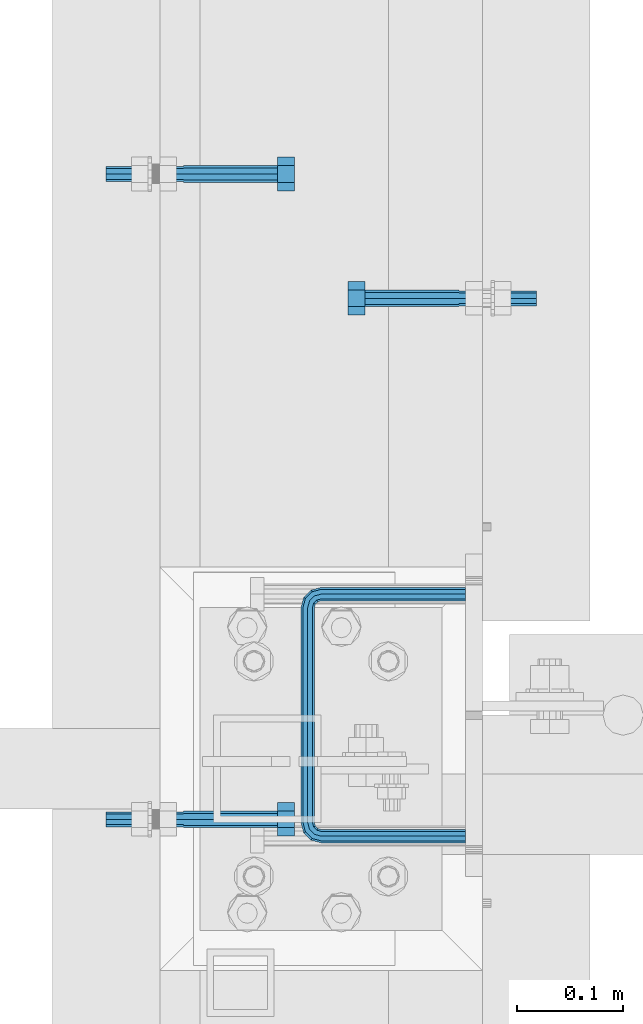
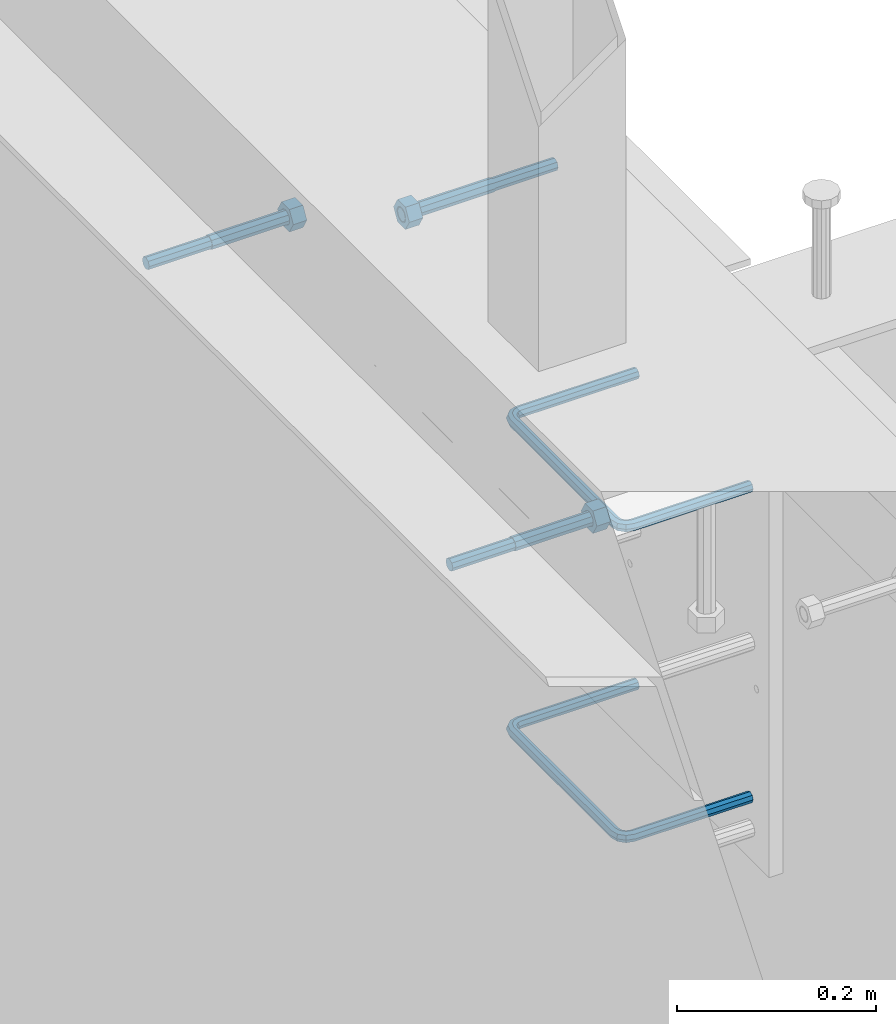
# One storey, part 397 of 975: 5 beams.
"""IFC2X3 building model written with IfcOpenShell, lengths in millimetres."""

from ifc_helpers import new_model, si_unit, frame, origin_with_axes, place, context, subcontext, project, spatial, faceted_brep, material, type_object, element, save


model = new_model("IFC2X3")

# Units and contexts
model_context = context("Model", 3, precision=1e-05, world=origin_with_axes())
body_context = subcontext(model_context, "Body", "Model", "MODEL_VIEW")
ifc_project = project(units=[si_unit("LENGTHUNIT", "METRE", prefix="MILLI"), si_unit("AREAUNIT", "SQUARE_METRE"), si_unit("VOLUMEUNIT", "CUBIC_METRE"), si_unit("MASSUNIT", "GRAM", prefix="KILO"), si_unit("TIMEUNIT", "SECOND"), si_unit("PLANEANGLEUNIT", "RADIAN"), si_unit("SOLIDANGLEUNIT", "STERADIAN"), si_unit("THERMODYNAMICTEMPERATUREUNIT", "DEGREE_CELSIUS"), si_unit("LUMINOUSINTENSITYUNIT", "LUMEN")], contexts=[model_context])

# Site, building, storey
site_placement = place(None, origin_with_axes())
site = spatial("IfcSite", under=ifc_project, at=site_placement, CompositionType="ELEMENT")
building_placement = place(site_placement, origin_with_axes())
building = spatial("IfcBuilding", under=site, at=building_placement, Name="Undefined", CompositionType="ELEMENT")
storey_placement = place(building_placement, origin_with_axes())
storey = spatial("IfcBuildingStorey", under=building, at=storey_placement, Name="Undefined", CompositionType="ELEMENT", Elevation=0.0)

# Beams
ifc_material_1 = material(Name="STEEL/F1554-36")
beam_type_1 = type_object("IfcBeamType", PredefinedType="NOTDEFINED")
beam_1_placement = place(storey_placement, frame((2038.35002654959, 13903.3250486621, 3835.4), z_axis=(0.0, 0.0, -1.0), x_axis=(1.0, 0.0, 0.0)))
element("IfcBeam", 1, at=beam_1_placement, inside=storey, type_object=beam_type_1, material=ifc_material_1, Name="HEADED_ANCHOR_BOLT", context=body_context, shape_type="Brep", body=[
    faceted_brep([(88.9000000184824, 7.94000001861696, -13.7499999799138), (88.8999999527368, 15.8800000758411, 2.00943759409711e-08), (104.774999952569, 15.8800001213949, 6.97191353538074e-08), (104.775000018315, 7.94000006417082, -13.7499999302891), (88.900000064019, -7.94000009583215, -13.7499999799147), (104.775000063852, -7.9400000502792, -13.74999993029), (88.9000000438027, -15.880000153059, 2.00925569515675e-08), (104.775000043643, -15.8800001075042, 6.9716406869702e-08), (88.8999999780608, -7.94000009583488, 13.7500000200998), (104.774999977893, -7.94000005028101, 13.7500000697237), (88.8999999325279, 7.94000001861514, 13.7500000201007), (104.774999932361, 7.940000064169, 13.7500000697246), (88.9000000119959, 3.78780480527439, -7.86545778426807), (88.8999999957159, 6.82538844544797, -5.4430656647246), (88.8999999799416, 8.51112018845743, -1.94260763148395), (88.8999999677944, 8.51112018845652, 1.94260767167179), (88.8999999616899, 6.82538844544615, 5.44306570491244), (88.8999999628249, 3.78780480527257, 7.86545782445592), (88.8999999709849, -3.86089595849626e-08, 8.72999956233434), (88.8999999845473, -3.7878048824914, 7.8654578244541), (88.9000000008309, -6.82538852266407, 5.44306570491153), (88.9000000166052, -8.51112026567444, 1.94260767166998), (88.9000000287488, -8.51112026567353, -1.94260763148577), (88.9000000348606, -6.82538852266407, -5.44306566472642), (88.9000000337182, -3.78780488248958, -7.86545778426898), (88.9000000255583, -3.86080500902608e-08, -8.72999952214832), (104.775000025395, 6.94581103743985e-09, -8.72999947252447), (104.775000011829, 3.78780485082825, -7.86545773464422), (104.774999995549, 6.82538849100092, -5.44306561510075), (104.774999979774, 8.51112023401038, -1.9426075818601), (104.774999967627, 8.51112023401038, 1.94260772129564), (104.774999961523, 6.82538849100092, 5.44306575453629), (104.774999962658, 3.78780485082643, 7.86545787407977), (104.774999970818, 6.94399204803631e-09, 8.7299996119591), (104.77499998438, -3.78780483693754, 7.86545787407886), (104.775000000664, -6.82538847711112, 5.44306575453538), (104.775000016438, -8.51112022012057, 1.94260772129473), (104.775000028581, -8.51112022012057, -1.94260758186101), (104.775000034693, -6.82538847711021, -5.44306561510166), (104.775000033551, -3.78780483693663, -7.86545773464422), (-2.99107341561466e-07, -5.61266007567065, 5.61266007566792), (-4.22995071858168e-07, -7.93750000000728, 0.0), (104.774999998088, -7.93749999999, -4.45652403868735e-11), (104.774999998088, -5.61266007565791, 5.61266007562426), (-1.09139364212751e-11, 1.81898940354586e-12, 7.9375), (104.774999998095, 1.18234311230481e-11, 7.93749999995816), (2.99089151667431e-07, 5.61266007567428, 5.61266007566792), (104.774999998102, 5.61266007568065, 5.61266007562517), (4.22980519942939e-07, 7.93750000001091, 0.0), (104.77499999811, 7.93750000001364, -4.36557456851006e-11), (2.99089151667431e-07, 5.61266007567428, -5.61266007566792), (104.774999998102, 5.61266007568156, -5.61266007571339), (-1.09139364212751e-11, 1.81898940354586e-12, -7.9375), (104.774999998099, 1.2732925824821e-11, -7.93750000004547), (-73.0249999592124, 5.05157065939329, -5.0515715445581), (-73.0249999269472, -1.85405951924622e-07, -7.14400069976364), (-73.0249999328516, -5.0515710302052, -5.05157154455992), (-73.0249999734697, -7.14400018541073, -6.9975976657588e-07), (-73.0250000250016, -5.05157103020611, 5.05157014504039), (-73.0250000572705, -1.85406861419324e-07, 7.1439993002441), (-73.0250000513661, 5.05157065939238, 5.05157014503948), (-73.025000010748, 7.14399981459792, -6.99758857081179e-07), (0.00625003290042514, 5.05157085007795, -5.05157087849238), (0.00625006516929716, 5.27870724909008e-09, -7.1440000336961), (0.00625005926485755, -5.05157083952145, -5.05157087849329), (0.00625001864682417, -7.14399999472516, -3.36940502165817e-08), (0.00624996711121639, -5.05157083952145, 5.05157081110519), (0.00624993484598235, 5.2777977543883e-09, 7.14399996631164), (0.00624994074678398, 5.05157085007704, 5.05157081110701), (0.00624998136845534, 7.14400000528167, -3.36922312271781e-08), (-2.99107341561466e-07, -5.61266007567065, -5.61266007566792), (104.774999998092, -5.612660075657, -5.6126600757143)], [[[0, 1, 2, 3]], [[4, 0, 3, 5]], [[6, 4, 5, 7]], [[8, 6, 7, 9]], [[10, 8, 9, 11]], [[0, 4, 6, 8, 10, 1], [12, 13, 14, 15, 16, 17, 18, 19, 20, 21, 22, 23, 24, 25]], [[12, 25, 26, 27]], [[13, 12, 27, 28]], [[14, 13, 28, 29]], [[15, 14, 29, 30]], [[16, 15, 30, 31]], [[17, 16, 31, 32]], [[18, 17, 32, 33]], [[19, 18, 33, 34]], [[20, 19, 34, 35]], [[21, 20, 35, 36]], [[22, 21, 36, 37]], [[23, 22, 37, 38]], [[24, 23, 38, 39]], [[25, 24, 39, 26]], [[9, 7, 5, 3, 2, 11], [38, 37, 36, 35, 34, 33, 32, 31, 30, 29, 28, 27, 26, 39]], [[1, 10, 11, 2]], [[40, 41, 42, 43]], [[44, 40, 43, 45]], [[46, 44, 45, 47]], [[48, 46, 47, 49]], [[50, 48, 49, 51]], [[52, 50, 51, 53]], [[54, 55, 56, 57, 58, 59, 60, 61]], [[55, 54, 62, 63]], [[56, 55, 63, 64]], [[57, 56, 64, 65]], [[58, 57, 65, 66]], [[59, 58, 66, 67]], [[60, 59, 67, 68]], [[61, 60, 68, 69]], [[54, 61, 69, 62]], [[40, 44, 46, 48, 50, 52, 70, 41], [68, 67, 66, 65, 64, 63, 62, 69]], [[41, 70, 71, 42]], [[53, 51, 49, 47, 45, 43, 42, 71]], [[70, 52, 53, 71]]]),
])
beam_2_placement = place(storey_placement, frame((2038.35002228239, 13293.7249510059, 3835.4), z_axis=(0.0, 0.0, -1.0), x_axis=(1.0, 0.0, 0.0)))
element("IfcBeam", 2, at=beam_2_placement, inside=storey, type_object=beam_type_1, material=ifc_material_1, Name="HEADED_ANCHOR_BOLT", context=body_context, shape_type="Brep", body=[
    faceted_brep([(88.9000000184824, 7.94000001861696, -13.7499999799138), (88.8999999527368, 15.8800000758411, 2.00943759409711e-08), (104.774999952569, 15.8800001213949, 6.97191353538074e-08), (104.775000018315, 7.94000006417082, -13.7499999302891), (88.900000064019, -7.94000009583215, -13.7499999799147), (104.775000063852, -7.9400000502792, -13.74999993029), (88.9000000438027, -15.880000153059, 2.00925569515675e-08), (104.775000043643, -15.8800001075042, 6.9716406869702e-08), (88.8999999780608, -7.94000009583488, 13.7500000200998), (104.774999977893, -7.94000005028101, 13.7500000697237), (88.8999999325279, 7.94000001861514, 13.7500000201007), (104.774999932361, 7.940000064169, 13.7500000697246), (88.9000000119959, 3.78780480527439, -7.86545778426807), (88.8999999957159, 6.82538844544797, -5.4430656647246), (88.8999999799416, 8.51112018845743, -1.94260763148395), (88.8999999677944, 8.51112018845652, 1.94260767167179), (88.8999999616899, 6.82538844544615, 5.44306570491244), (88.8999999628249, 3.78780480527257, 7.86545782445592), (88.8999999709849, -3.86089595849626e-08, 8.72999956233434), (88.8999999845473, -3.7878048824914, 7.8654578244541), (88.9000000008309, -6.82538852266407, 5.44306570491153), (88.9000000166052, -8.51112026567444, 1.94260767166998), (88.9000000287488, -8.51112026567353, -1.94260763148577), (88.9000000348606, -6.82538852266407, -5.44306566472642), (88.9000000337182, -3.78780488248958, -7.86545778426898), (88.9000000255583, -3.86080500902608e-08, -8.72999952214832), (104.775000025395, 6.94581103743985e-09, -8.72999947252447), (104.775000011829, 3.78780485082825, -7.86545773464422), (104.774999995549, 6.82538849100092, -5.44306561510075), (104.774999979774, 8.51112023401038, -1.9426075818601), (104.774999967627, 8.51112023401038, 1.94260772129564), (104.774999961523, 6.82538849100092, 5.44306575453629), (104.774999962658, 3.78780485082643, 7.86545787407977), (104.774999970818, 6.94399204803631e-09, 8.7299996119591), (104.77499998438, -3.78780483693754, 7.86545787407886), (104.775000000664, -6.82538847711112, 5.44306575453538), (104.775000016438, -8.51112022012057, 1.94260772129473), (104.775000028581, -8.51112022012057, -1.94260758186101), (104.775000034693, -6.82538847711021, -5.44306561510166), (104.775000033551, -3.78780483693663, -7.86545773464422), (-2.99107341561466e-07, -5.61266007567065, 5.61266007566792), (-4.22995071858168e-07, -7.93750000000728, 0.0), (104.774999998088, -7.93749999999, -4.45652403868735e-11), (104.774999998088, -5.61266007565791, 5.61266007562426), (-1.09139364212751e-11, 1.81898940354586e-12, 7.9375), (104.774999998095, 1.18234311230481e-11, 7.93749999995816), (2.99089151667431e-07, 5.61266007567428, 5.61266007566792), (104.774999998102, 5.61266007568065, 5.61266007562517), (4.22980519942939e-07, 7.93750000001091, 0.0), (104.77499999811, 7.93750000001364, -4.36557456851006e-11), (2.99089151667431e-07, 5.61266007567428, -5.61266007566792), (104.774999998102, 5.61266007568156, -5.61266007571339), (-1.09139364212751e-11, 1.81898940354586e-12, -7.9375), (104.774999998099, 1.2732925824821e-11, -7.93750000004547), (-73.0249999592124, 5.05157065939329, -5.0515715445581), (-73.0249999269472, -1.85405951924622e-07, -7.14400069976364), (-73.0249999328516, -5.0515710302052, -5.05157154455992), (-73.0249999734697, -7.14400018541073, -6.9975976657588e-07), (-73.0250000250016, -5.05157103020611, 5.05157014504039), (-73.0250000572705, -1.85406861419324e-07, 7.1439993002441), (-73.0250000513661, 5.05157065939238, 5.05157014503948), (-73.025000010748, 7.14399981459792, -6.99758857081179e-07), (0.00625003290042514, 5.05157085007795, -5.05157087849238), (0.00625006516929716, 5.27870724909008e-09, -7.1440000336961), (0.00625005926485755, -5.05157083952145, -5.05157087849329), (0.00625001864682417, -7.14399999472516, -3.36940502165817e-08), (0.00624996711121639, -5.05157083952145, 5.05157081110519), (0.00624993484598235, 5.2777977543883e-09, 7.14399996631164), (0.00624994074678398, 5.05157085007704, 5.05157081110701), (0.00624998136845534, 7.14400000528167, -3.36922312271781e-08), (-2.99107341561466e-07, -5.61266007567065, -5.61266007566792), (104.774999998092, -5.612660075657, -5.6126600757143)], [[[0, 1, 2, 3]], [[4, 0, 3, 5]], [[6, 4, 5, 7]], [[8, 6, 7, 9]], [[10, 8, 9, 11]], [[0, 4, 6, 8, 10, 1], [12, 13, 14, 15, 16, 17, 18, 19, 20, 21, 22, 23, 24, 25]], [[12, 25, 26, 27]], [[13, 12, 27, 28]], [[14, 13, 28, 29]], [[15, 14, 29, 30]], [[16, 15, 30, 31]], [[17, 16, 31, 32]], [[18, 17, 32, 33]], [[19, 18, 33, 34]], [[20, 19, 34, 35]], [[21, 20, 35, 36]], [[22, 21, 36, 37]], [[23, 22, 37, 38]], [[24, 23, 38, 39]], [[25, 24, 39, 26]], [[9, 7, 5, 3, 2, 11], [38, 37, 36, 35, 34, 33, 32, 31, 30, 29, 28, 27, 26, 39]], [[1, 10, 11, 2]], [[40, 41, 42, 43]], [[44, 40, 43, 45]], [[46, 44, 45, 47]], [[48, 46, 47, 49]], [[50, 48, 49, 51]], [[52, 50, 51, 53]], [[54, 55, 56, 57, 58, 59, 60, 61]], [[55, 54, 62, 63]], [[56, 55, 63, 64]], [[57, 56, 64, 65]], [[58, 57, 65, 66]], [[59, 58, 66, 67]], [[60, 59, 67, 68]], [[61, 60, 68, 69]], [[54, 61, 69, 62]], [[40, 44, 46, 48, 50, 52, 70, 41], [68, 67, 66, 65, 64, 63, 62, 69]], [[41, 70, 71, 42]], [[53, 51, 49, 47, 45, 43, 42, 71]], [[70, 52, 53, 71]]]),
])
beam_3_placement = place(storey_placement, frame((2298.70002900036, 13785.8499761124, 3886.2), z_axis=(0.0, 0.0, 1.0), x_axis=(-0.999999999999998, 6.90000001668524e-08, 0.0)))
element("IfcBeam", 3, at=beam_3_placement, inside=storey, type_object=beam_type_1, material=ifc_material_1, Name="HEADED_ANCHOR_BOLT", context=body_context, shape_type="Brep", body=[
    faceted_brep([(88.9000000184824, 7.94000001861696, -13.7499999799138), (88.8999999527368, 15.8800000758411, 2.00943759409711e-08), (104.774999952569, 15.8800001213949, 6.97191353538074e-08), (104.775000018315, 7.94000006417082, -13.7499999302891), (88.900000064019, -7.94000009583215, -13.7499999799147), (104.775000063852, -7.9400000502792, -13.74999993029), (88.9000000438027, -15.880000153059, 2.00925569515675e-08), (104.775000043643, -15.8800001075042, 6.9716406869702e-08), (88.8999999780608, -7.94000009583488, 13.7500000200998), (104.774999977893, -7.94000005028101, 13.7500000697237), (88.8999999325279, 7.94000001861514, 13.7500000201007), (104.774999932361, 7.940000064169, 13.7500000697246), (88.9000000119959, 3.78780480527439, -7.86545778426807), (88.8999999957159, 6.82538844544797, -5.4430656647246), (88.8999999799416, 8.51112018845743, -1.94260763148395), (88.8999999677944, 8.51112018845652, 1.94260767167179), (88.8999999616899, 6.82538844544615, 5.44306570491244), (88.8999999628249, 3.78780480527257, 7.86545782445592), (88.8999999709849, -3.86089595849626e-08, 8.72999956233434), (88.8999999845473, -3.7878048824914, 7.8654578244541), (88.9000000008309, -6.82538852266407, 5.44306570491153), (88.9000000166052, -8.51112026567444, 1.94260767166998), (88.9000000287488, -8.51112026567353, -1.94260763148577), (88.9000000348606, -6.82538852266407, -5.44306566472642), (88.9000000337182, -3.78780488248958, -7.86545778426898), (88.9000000255583, -3.86080500902608e-08, -8.72999952214832), (104.775000025395, 6.94581103743985e-09, -8.72999947252447), (104.775000011829, 3.78780485082825, -7.86545773464422), (104.774999995549, 6.82538849100092, -5.44306561510075), (104.774999979774, 8.51112023401038, -1.9426075818601), (104.774999967627, 8.51112023401038, 1.94260772129564), (104.774999961523, 6.82538849100092, 5.44306575453629), (104.774999962658, 3.78780485082643, 7.86545787407977), (104.774999970818, 6.94399204803631e-09, 8.7299996119591), (104.77499998438, -3.78780483693754, 7.86545787407886), (104.775000000664, -6.82538847711112, 5.44306575453538), (104.775000016438, -8.51112022012057, 1.94260772129473), (104.775000028581, -8.51112022012057, -1.94260758186101), (104.775000034693, -6.82538847711021, -5.44306561510166), (104.775000033551, -3.78780483693663, -7.86545773464422), (-2.99107341561466e-07, -5.61266007567065, 5.61266007566792), (-4.22995071858168e-07, -7.93750000000728, 0.0), (104.774999998088, -7.93749999999, -4.45652403868735e-11), (104.774999998088, -5.61266007565791, 5.61266007562426), (-1.09139364212751e-11, 1.81898940354586e-12, 7.9375), (104.774999998095, 1.18234311230481e-11, 7.93749999995816), (2.99089151667431e-07, 5.61266007567428, 5.61266007566792), (104.774999998102, 5.61266007568065, 5.61266007562517), (4.22980519942939e-07, 7.93750000001091, 0.0), (104.77499999811, 7.93750000001364, -4.36557456851006e-11), (2.99089151667431e-07, 5.61266007567428, -5.61266007566792), (104.774999998102, 5.61266007568156, -5.61266007571339), (-1.09139364212751e-11, 1.81898940354586e-12, -7.9375), (104.774999998099, 1.2732925824821e-11, -7.93750000004547), (-73.0249999592124, 5.05157065939329, -5.0515715445581), (-73.0249999269472, -1.85405951924622e-07, -7.14400069976364), (-73.0249999328516, -5.0515710302052, -5.05157154455992), (-73.0249999734697, -7.14400018541073, -6.9975976657588e-07), (-73.0250000250016, -5.05157103020611, 5.05157014504039), (-73.0250000572705, -1.85406861419324e-07, 7.1439993002441), (-73.0250000513661, 5.05157065939238, 5.05157014503948), (-73.025000010748, 7.14399981459792, -6.99758857081179e-07), (0.00625003290042514, 5.05157085007795, -5.05157087849238), (0.00625006516929716, 5.27870724909008e-09, -7.1440000336961), (0.00625005926485755, -5.05157083952145, -5.05157087849329), (0.00625001864682417, -7.14399999472516, -3.36940502165817e-08), (0.00624996711121639, -5.05157083952145, 5.05157081110519), (0.00624993484598235, 5.2777977543883e-09, 7.14399996631164), (0.00624994074678398, 5.05157085007704, 5.05157081110701), (0.00624998136845534, 7.14400000528167, -3.36922312271781e-08), (-2.99107341561466e-07, -5.61266007567065, -5.61266007566792), (104.774999998092, -5.612660075657, -5.6126600757143)], [[[0, 1, 2, 3]], [[4, 0, 3, 5]], [[6, 4, 5, 7]], [[8, 6, 7, 9]], [[10, 8, 9, 11]], [[0, 4, 6, 8, 10, 1], [12, 13, 14, 15, 16, 17, 18, 19, 20, 21, 22, 23, 24, 25]], [[12, 25, 26, 27]], [[13, 12, 27, 28]], [[14, 13, 28, 29]], [[15, 14, 29, 30]], [[16, 15, 30, 31]], [[17, 16, 31, 32]], [[18, 17, 32, 33]], [[19, 18, 33, 34]], [[20, 19, 34, 35]], [[21, 20, 35, 36]], [[22, 21, 36, 37]], [[23, 22, 37, 38]], [[24, 23, 38, 39]], [[25, 24, 39, 26]], [[9, 7, 5, 3, 2, 11], [38, 37, 36, 35, 34, 33, 32, 31, 30, 29, 28, 27, 26, 39]], [[1, 10, 11, 2]], [[40, 41, 42, 43]], [[44, 40, 43, 45]], [[46, 44, 45, 47]], [[48, 46, 47, 49]], [[50, 48, 49, 51]], [[52, 50, 51, 53]], [[54, 55, 56, 57, 58, 59, 60, 61]], [[55, 54, 62, 63]], [[56, 55, 63, 64]], [[57, 56, 64, 65]], [[58, 57, 65, 66]], [[59, 58, 66, 67]], [[60, 59, 67, 68]], [[61, 60, 68, 69]], [[54, 61, 69, 62]], [[40, 44, 46, 48, 50, 52, 70, 41], [68, 67, 66, 65, 64, 63, 62, 69]], [[41, 70, 71, 42]], [[53, 51, 49, 47, 45, 43, 42, 71]], [[70, 52, 53, 71]]]),
])
ifc_material_2 = material(Name="STEEL/A706")
beam_type_2 = type_object("IfcBeamType", Name="#4 TIE", PredefinedType="NOTDEFINED")
beam_4_placement = place(storey_placement, frame((2305.05, 13277.8499969482, 3441.69998779297), z_axis=(0.0, 1.0, 0.0), x_axis=(-0.999999999999998, 6.90000001668524e-08, 0.0)))
element("IfcBeam", 4, at=beam_4_placement, inside=storey, type_object=beam_type_2, material=ifc_material_2, Name="TIE ROD", ObjectType="#4 TIE", context=body_context, shape_type="Brep", body=[
    faceted_brep([(0.0, -6.34999999998763, -3.63797880709171e-12), (0.0, -4.49012806052269, -4.49012806054634), (136.525006144455, -4.49012806053452, -4.49012811661669), (136.525006146271, -6.35000000000036, -5.60821717954241e-08), (0.0, 7.27595761418343e-12, -6.35000000000764), (136.525006143703, 0.0, -6.35000005608254), (0.0, 4.49012806053724, -4.49012806053906), (136.525006144455, 4.49012806053452, -4.49012811661669), (0.0, 6.34999999999491, 5.45696821063757e-12), (136.525006146271, 6.35000000000036, -5.60821717954241e-08), (0.0, 4.49012806052633, 4.49012806054634), (136.525006148087, 4.49012806053452, 4.49012800445234), (0.0, 0.0, 6.35000000000764), (136.525006148839, 0.0, 6.34999994391819), (0.0, -4.49012806053361, 4.49012806053543), (136.525006148087, -4.49012806053452, 4.49012800445234), (146.050006113442, 0.0, -3.79778399058796), (145.120070138105, -4.49012806053452, -2.1870876464609), (142.875006094308, -6.35000000000036, 1.70147731239558), (140.62994205051, -4.49012806053452, 5.59004227125297), (139.700006075173, 0.0, 7.20073861538003), (140.62994205051, 4.49012806053452, 5.59004227125297), (142.875006094308, 6.35000000000036, 1.70147731239558), (145.120070138105, 4.49012806053452, -2.1870876464609), (151.412093644245, 4.49012806053452, 4.10493592790226), (153.022789998455, 0.0, 3.1749999700296), (147.523528661045, 6.35000000000036, 6.34999992953635), (143.634963677846, 4.49012806053452, 8.59506393117135), (142.024267323636, 0.0, 9.5249998890431), (143.634963677846, -4.49012806053452, 8.59506393117135), (147.523528661045, -6.35000000000036, 6.34999992953635), (151.412093644245, -4.49012806053452, 4.10493592790226), (153.715134021207, 4.49012806053452, 12.6999999465306), (155.575005960673, 0.0, 12.6999999674508), (149.225005960672, 6.35000000000036, 12.6999998960273), (144.734877900137, 4.49012806053452, 12.699999845524), (142.875005960672, 0.0, 12.6999998246056), (144.734877900137, -4.49012806053452, 12.699999845524), (149.225005960671, -6.35000000000036, 12.6999998960273), (153.715134021207, -4.49012806053452, 12.6999999465306), (153.71513173569, -4.49012806053452, 215.900003176369), (149.225003675155, -6.35000000000036, 215.900003125867), (155.575003675155, 0.0, 215.900003197289), (153.71513173569, 4.49012806053452, 215.900003176369), (149.225003675155, 6.35000000000036, 215.900003125867), (144.734875614621, 4.49012806053452, 215.900003075363), (142.875003675155, 0.0, 215.900003054444), (144.734875614621, -4.49012806053452, 215.900003075363), (153.022787648382, 0.0, 225.425002877988), (151.412091300475, -4.49012806053452, 224.495066909199), (147.523526332491, -6.35000000000036, 222.25000288121), (143.634961364508, -4.49012806053452, 220.004938853222), (142.024265016601, 0.0, 219.075002884432), (143.634961364508, 4.49012806053452, 220.004938853222), (147.523526332491, 6.35000000000036, 222.25000288121), (151.412091300475, 4.49012806053452, 224.495066909199), (145.120067985683, 4.49012806053452, 230.787090305822), (146.05000397542, 0.0, 232.397786641635), (142.875003907121, 6.35000000000036, 226.898525367037), (140.629939828559, 4.49012806053452, 223.00996042825), (139.700003838822, 0.0, 221.399264092438), (140.629939828559, -4.49012806053452, 223.00996042825), (142.875003907121, -6.35000000000036, 226.898525367037), (145.120067985683, -4.49012806053452, 230.787090305822), (136.525004282814, 4.49012806053452, 233.090130852819), (136.525004327922, 0.0, 234.950002792285), (136.525004173912, 6.35000000000036, 228.600002792285), (136.52500406501, 4.49012806053452, 224.10987473175), (136.525004019901, 0.0, 222.250002792285), (136.52500406501, -4.49012806053452, 224.10987473175), (136.525004173912, -6.35000000000036, 228.600002792286), (136.525004282814, -4.49012806053452, 233.090130852819), (3.32236731992452e-06, -4.49012806053452, 233.090134164055), (3.21346533382894e-06, -6.35000000000036, 228.60000610352), (3.36747552864836e-06, 0.0, 234.95000610352), (3.32236731992452e-06, 4.49012806053452, 233.090134164055), (3.21346533382894e-06, 6.35000000000036, 228.60000610352), (3.104562892986e-06, 4.49012806053452, 224.109878042986), (3.05945422951481e-06, 0.0, 222.25000610352), (3.104562892986e-06, -4.49012806053452, 224.109878042986)], [[[0, 1, 2, 3]], [[1, 4, 5, 2]], [[4, 6, 7, 5]], [[6, 8, 9, 7]], [[8, 10, 11, 9]], [[10, 12, 13, 11]], [[12, 14, 15, 13]], [[14, 0, 3, 15]], [[14, 12, 10, 8, 6, 4, 1, 0]], [[2, 5, 16, 17]], [[3, 2, 17, 18]], [[15, 3, 18, 19]], [[13, 15, 19, 20]], [[11, 13, 20, 21]], [[9, 11, 21, 22]], [[7, 9, 22, 23]], [[5, 7, 23, 16]], [[23, 24, 25, 16]], [[22, 26, 24, 23]], [[21, 27, 26, 22]], [[20, 28, 27, 21]], [[19, 29, 28, 20]], [[18, 30, 29, 19]], [[17, 31, 30, 18]], [[16, 25, 31, 17]], [[24, 32, 33, 25]], [[26, 34, 32, 24]], [[27, 35, 34, 26]], [[28, 36, 35, 27]], [[29, 37, 36, 28]], [[30, 38, 37, 29]], [[31, 39, 38, 30]], [[25, 33, 39, 31]], [[38, 39, 40, 41]], [[39, 33, 42, 40]], [[33, 32, 43, 42]], [[32, 34, 44, 43]], [[34, 35, 45, 44]], [[35, 36, 46, 45]], [[36, 37, 47, 46]], [[37, 38, 41, 47]], [[40, 42, 48, 49]], [[41, 40, 49, 50]], [[47, 41, 50, 51]], [[46, 47, 51, 52]], [[45, 46, 52, 53]], [[44, 45, 53, 54]], [[43, 44, 54, 55]], [[42, 43, 55, 48]], [[55, 56, 57, 48]], [[54, 58, 56, 55]], [[53, 59, 58, 54]], [[52, 60, 59, 53]], [[51, 61, 60, 52]], [[50, 62, 61, 51]], [[49, 63, 62, 50]], [[48, 57, 63, 49]], [[56, 64, 65, 57]], [[58, 66, 64, 56]], [[59, 67, 66, 58]], [[60, 68, 67, 59]], [[61, 69, 68, 60]], [[62, 70, 69, 61]], [[63, 71, 70, 62]], [[57, 65, 71, 63]], [[70, 71, 72, 73]], [[71, 65, 74, 72]], [[65, 64, 75, 74]], [[64, 66, 76, 75]], [[66, 67, 77, 76]], [[67, 68, 78, 77]], [[68, 69, 79, 78]], [[69, 70, 73, 79]], [[74, 75, 76, 77, 78, 79, 73, 72]]]),
])
beam_5_placement = place(storey_placement, frame((2305.05, 13277.8499969482, 3822.7), z_axis=(0.0, 1.0, 0.0), x_axis=(-0.999999999999998, 6.90000001668524e-08, 0.0)))
element("IfcBeam", 5, at=beam_5_placement, inside=storey, type_object=beam_type_2, material=ifc_material_2, Name="TIE ROD", ObjectType="#4 TIE", context=body_context, shape_type="Brep", body=[
    faceted_brep([(0.0, -6.34999999998763, -3.63797880709171e-12), (0.0, -4.49012806052269, -4.49012806054634), (136.525006144455, -4.49012806053452, -4.49012811661669), (136.525006146271, -6.35000000000036, -5.60821717954241e-08), (0.0, 7.27595761418343e-12, -6.35000000000764), (136.525006143703, 0.0, -6.35000005608254), (0.0, 4.49012806053724, -4.49012806053906), (136.525006144455, 4.49012806053452, -4.49012811661669), (0.0, 6.34999999999491, 5.45696821063757e-12), (136.525006146271, 6.35000000000036, -5.60821717954241e-08), (0.0, 4.49012806052633, 4.49012806054634), (136.525006148087, 4.49012806053452, 4.49012800445234), (0.0, 0.0, 6.35000000000764), (136.525006148839, 0.0, 6.34999994391819), (0.0, -4.49012806053361, 4.49012806053543), (136.525006148087, -4.49012806053452, 4.49012800445234), (146.050006113442, 0.0, -3.79778399058796), (145.120070138105, -4.49012806053452, -2.1870876464609), (142.875006094308, -6.35000000000036, 1.70147731239558), (140.62994205051, -4.49012806053452, 5.59004227125297), (139.700006075173, 0.0, 7.20073861538003), (140.62994205051, 4.49012806053452, 5.59004227125297), (142.875006094308, 6.35000000000036, 1.70147731239558), (145.120070138105, 4.49012806053452, -2.1870876464609), (151.412093644245, 4.49012806053452, 4.10493592790226), (153.022789998455, 0.0, 3.1749999700296), (147.523528661045, 6.35000000000036, 6.34999992953635), (143.634963677846, 4.49012806053452, 8.59506393117135), (142.024267323636, 0.0, 9.5249998890431), (143.634963677846, -4.49012806053452, 8.59506393117135), (147.523528661045, -6.35000000000036, 6.34999992953635), (151.412093644245, -4.49012806053452, 4.10493592790226), (153.715134021207, 4.49012806053452, 12.6999999465306), (155.575005960673, 0.0, 12.6999999674508), (149.225005960672, 6.35000000000036, 12.6999998960273), (144.734877900137, 4.49012806053452, 12.699999845524), (142.875005960672, 0.0, 12.6999998246056), (144.734877900137, -4.49012806053452, 12.699999845524), (149.225005960671, -6.35000000000036, 12.6999998960273), (153.715134021207, -4.49012806053452, 12.6999999465306), (153.71513173569, -4.49012806053452, 215.900003176369), (149.225003675155, -6.35000000000036, 215.900003125867), (155.575003675155, 0.0, 215.900003197289), (153.71513173569, 4.49012806053452, 215.900003176369), (149.225003675155, 6.35000000000036, 215.900003125867), (144.734875614621, 4.49012806053452, 215.900003075363), (142.875003675155, 0.0, 215.900003054444), (144.734875614621, -4.49012806053452, 215.900003075363), (153.022787648382, 0.0, 225.425002877988), (151.412091300475, -4.49012806053452, 224.495066909199), (147.523526332491, -6.35000000000036, 222.25000288121), (143.634961364508, -4.49012806053452, 220.004938853222), (142.024265016601, 0.0, 219.075002884432), (143.634961364508, 4.49012806053452, 220.004938853222), (147.523526332491, 6.35000000000036, 222.25000288121), (151.412091300475, 4.49012806053452, 224.495066909199), (145.120067985683, 4.49012806053452, 230.787090305822), (146.05000397542, 0.0, 232.397786641635), (142.875003907121, 6.35000000000036, 226.898525367037), (140.629939828559, 4.49012806053452, 223.00996042825), (139.700003838822, 0.0, 221.399264092438), (140.629939828559, -4.49012806053452, 223.00996042825), (142.875003907121, -6.35000000000036, 226.898525367037), (145.120067985683, -4.49012806053452, 230.787090305822), (136.525004282814, 4.49012806053452, 233.090130852819), (136.525004327922, 0.0, 234.950002792285), (136.525004173912, 6.35000000000036, 228.600002792285), (136.52500406501, 4.49012806053452, 224.10987473175), (136.525004019901, 0.0, 222.250002792285), (136.52500406501, -4.49012806053452, 224.10987473175), (136.525004173912, -6.35000000000036, 228.600002792286), (136.525004282814, -4.49012806053452, 233.090130852819), (3.32236731992452e-06, -4.49012806053452, 233.090134164055), (3.21346533382894e-06, -6.35000000000036, 228.60000610352), (3.36747552864836e-06, 0.0, 234.95000610352), (3.32236731992452e-06, 4.49012806053452, 233.090134164055), (3.21346533382894e-06, 6.35000000000036, 228.60000610352), (3.104562892986e-06, 4.49012806053452, 224.109878042986), (3.05945422951481e-06, 0.0, 222.25000610352), (3.104562892986e-06, -4.49012806053452, 224.109878042986)], [[[0, 1, 2, 3]], [[1, 4, 5, 2]], [[4, 6, 7, 5]], [[6, 8, 9, 7]], [[8, 10, 11, 9]], [[10, 12, 13, 11]], [[12, 14, 15, 13]], [[14, 0, 3, 15]], [[14, 12, 10, 8, 6, 4, 1, 0]], [[2, 5, 16, 17]], [[3, 2, 17, 18]], [[15, 3, 18, 19]], [[13, 15, 19, 20]], [[11, 13, 20, 21]], [[9, 11, 21, 22]], [[7, 9, 22, 23]], [[5, 7, 23, 16]], [[23, 24, 25, 16]], [[22, 26, 24, 23]], [[21, 27, 26, 22]], [[20, 28, 27, 21]], [[19, 29, 28, 20]], [[18, 30, 29, 19]], [[17, 31, 30, 18]], [[16, 25, 31, 17]], [[24, 32, 33, 25]], [[26, 34, 32, 24]], [[27, 35, 34, 26]], [[28, 36, 35, 27]], [[29, 37, 36, 28]], [[30, 38, 37, 29]], [[31, 39, 38, 30]], [[25, 33, 39, 31]], [[38, 39, 40, 41]], [[39, 33, 42, 40]], [[33, 32, 43, 42]], [[32, 34, 44, 43]], [[34, 35, 45, 44]], [[35, 36, 46, 45]], [[36, 37, 47, 46]], [[37, 38, 41, 47]], [[40, 42, 48, 49]], [[41, 40, 49, 50]], [[47, 41, 50, 51]], [[46, 47, 51, 52]], [[45, 46, 52, 53]], [[44, 45, 53, 54]], [[43, 44, 54, 55]], [[42, 43, 55, 48]], [[55, 56, 57, 48]], [[54, 58, 56, 55]], [[53, 59, 58, 54]], [[52, 60, 59, 53]], [[51, 61, 60, 52]], [[50, 62, 61, 51]], [[49, 63, 62, 50]], [[48, 57, 63, 49]], [[56, 64, 65, 57]], [[58, 66, 64, 56]], [[59, 67, 66, 58]], [[60, 68, 67, 59]], [[61, 69, 68, 60]], [[62, 70, 69, 61]], [[63, 71, 70, 62]], [[57, 65, 71, 63]], [[70, 71, 72, 73]], [[71, 65, 74, 72]], [[65, 64, 75, 74]], [[64, 66, 76, 75]], [[66, 67, 77, 76]], [[67, 68, 78, 77]], [[68, 69, 79, 78]], [[69, 70, 73, 79]], [[74, 75, 76, 77, 78, 79, 73, 72]]]),
])

save(model, "model.ifc")
